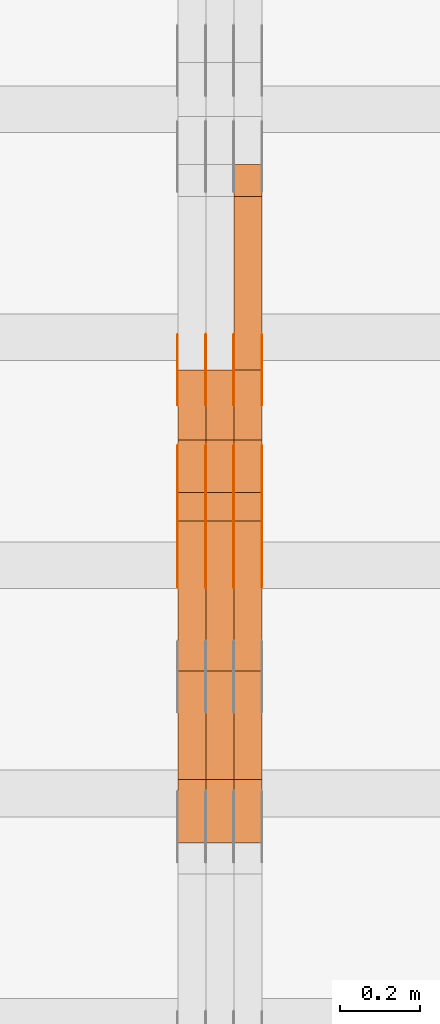
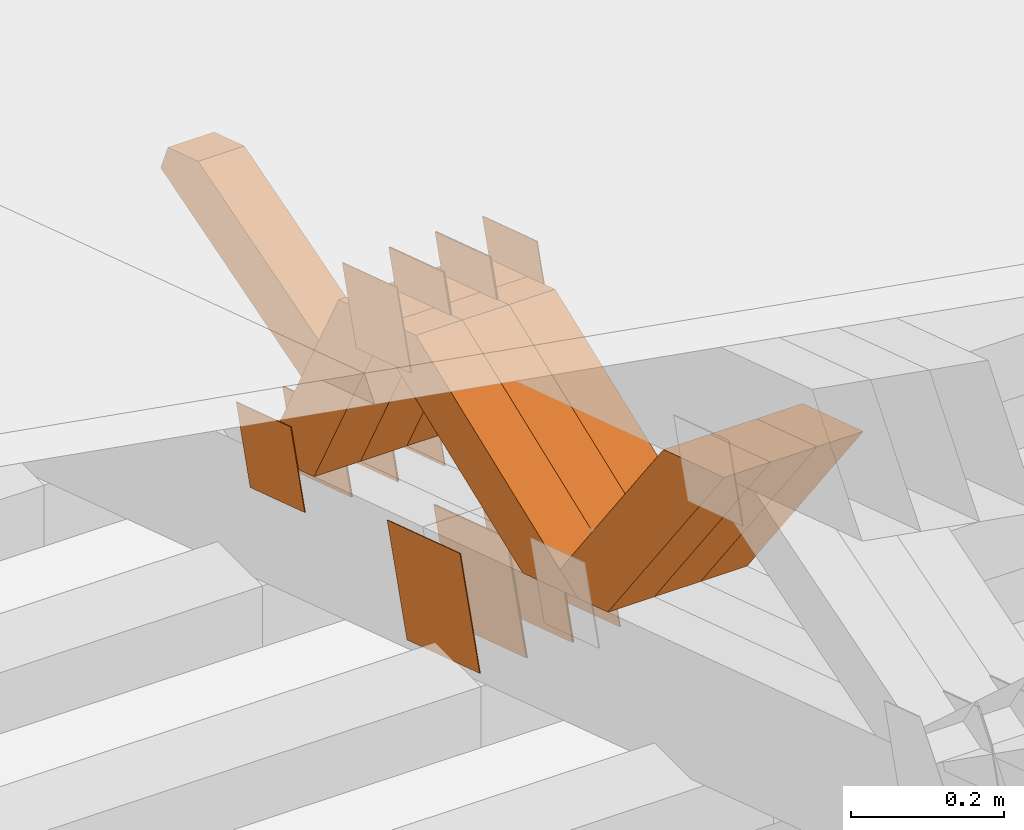
# One storey, part 216 of 385: 28 proxies.
"""IFC2X3 building model written with IfcOpenShell, lengths in millimetres."""

from ifc_helpers import new_model, entity, si_unit, converted_unit, derived_unit, direction, frame, origin, place, context, subcontext, project, spatial, polyline, outline, extrude, source, transform, mapped, material, type_object, type_shapes, element, save


model = new_model("IFC2X3")

# Units and contexts
model_context = context("Model", 3, precision=0.01, world=origin(), true_north=direction((6.12303176911189e-17, 1.0)))
body_context = subcontext(model_context, "Body", "Model", "MODEL_VIEW")
ifc_project = project(units=[si_unit("LENGTHUNIT", "METRE", prefix="MILLI"), si_unit("AREAUNIT", "SQUARE_METRE"), si_unit("VOLUMEUNIT", "CUBIC_METRE"), converted_unit("PLANEANGLEUNIT", "DEGREE", entity("IfcRatioMeasure", 0.0174532925199433), si_unit("PLANEANGLEUNIT", "RADIAN"), dimensions=[0, 0, 0, 0, 0, 0, 0]), si_unit("MASSUNIT", "GRAM", prefix="KILO"), derived_unit("MASSDENSITYUNIT", [(si_unit("MASSUNIT", "GRAM", prefix="KILO"), 1), (si_unit("LENGTHUNIT", "METRE"), -3)]), si_unit("TIMEUNIT", "SECOND"), si_unit("FREQUENCYUNIT", "HERTZ"), si_unit("THERMODYNAMICTEMPERATUREUNIT", "DEGREE_CELSIUS"), derived_unit("THERMALTRANSMITTANCEUNIT", [(si_unit("MASSUNIT", "GRAM", prefix="KILO"), 1), (si_unit("THERMODYNAMICTEMPERATUREUNIT", "KELVIN"), -1), (si_unit("TIMEUNIT", "SECOND"), -3)]), derived_unit("VOLUMETRICFLOWRATEUNIT", [(si_unit("LENGTHUNIT", "METRE"), 3), (si_unit("TIMEUNIT", "SECOND"), -1)]), si_unit("ELECTRICCURRENTUNIT", "AMPERE"), si_unit("ELECTRICVOLTAGEUNIT", "VOLT"), si_unit("POWERUNIT", "WATT"), si_unit("FORCEUNIT", "NEWTON", prefix="KILO"), si_unit("ILLUMINANCEUNIT", "LUX"), si_unit("LUMINOUSFLUXUNIT", "LUMEN"), si_unit("LUMINOUSINTENSITYUNIT", "CANDELA"), derived_unit("USERDEFINED", [(si_unit("MASSUNIT", "GRAM", prefix="KILO"), -1), (si_unit("LENGTHUNIT", "METRE"), -2), (si_unit("TIMEUNIT", "SECOND"), 3), (si_unit("LUMINOUSFLUXUNIT", "LUMEN"), 1)]), derived_unit("LINEARVELOCITYUNIT", [(si_unit("LENGTHUNIT", "METRE"), 1), (si_unit("TIMEUNIT", "SECOND"), -1)]), si_unit("PRESSUREUNIT", "PASCAL"), derived_unit("USERDEFINED", [(si_unit("LENGTHUNIT", "METRE"), -2), (si_unit("MASSUNIT", "GRAM", prefix="KILO"), 1), (si_unit("TIMEUNIT", "SECOND"), -2)])], contexts=[model_context])

# Site, building, storey
site_placement = place(None, origin())
site = spatial("IfcSite", under=ifc_project, at=site_placement, CompositionType="ELEMENT")
building_placement = place(site_placement, origin())
building = spatial("IfcBuilding", under=site, at=building_placement, CompositionType="ELEMENT")
storey_placement = place(building_placement, origin())
storey = spatial("IfcBuildingStorey", under=building, at=storey_placement, Name="Default", CompositionType="ELEMENT", Elevation=0.0)

# Proxies
ifc_material_1 = material(Name="IfcSurfaceStyle #275268")
building_element_proxy_type_1 = type_object("IfcBuildingElementProxyType", PredefinedType="NOTDEFINED", material=ifc_material_1)
shared_shape_1 = source(origin(), body_context, "Body", "SweptSolid", [
    extrude(outline(polyline([(-74.9998794200123, -59.999984515643), (74.9998565677174, -59.999984515643), (74.9998794200123, 59.999984515643), (-74.9998565677174, 59.999984515643), (-74.9998794200123, -59.999984515643)])), frame((75.0000769557496, 60.0000596852268, 0.0), z_axis=(0.0, 0.0, 1.0), x_axis=(-1.0, 0.0, 0.0)), (0.0, 0.0, 1.0), 1.3),
])
type_shapes(building_element_proxy_type_1, [shared_shape_1])
proxy_1_placement = place(building_placement, frame((21386.3, 22649.3668870864, 1282.62115477841), z_axis=(-1.0, 0.0, 0.0), x_axis=(0.0, -0.951056516295124, 0.309016994375039)))
element("IfcBuildingElementProxy", 1, at=proxy_1_placement, inside=storey, type_object=building_element_proxy_type_1, material=ifc_material_1, context=body_context, shape_type="MappedRepresentation", body=[
    mapped(shared_shape_1, transform((0.0, 0.0, 0.0), scale=1.0)),
])
ifc_material_2 = material(Name="IfcSurfaceStyle #275211")
building_element_proxy_type_2 = type_object("IfcBuildingElementProxyType", PredefinedType="NOTDEFINED", material=ifc_material_2)
shared_shape_2 = source(origin(), body_context, "Body", "SweptSolid", [
    extrude(outline(polyline([(-74.9998794200123, -59.999984515643), (74.9998565677174, -59.999984515643), (74.9998794200123, 59.999984515643), (-74.9998565677174, 59.999984515643), (-74.9998794200123, -59.999984515643)])), frame((75.0000769557496, 60.0000596852268, 0.0), z_axis=(0.0, 0.0, 1.0), x_axis=(-1.0, 0.0, 0.0)), (0.0, 0.0, 1.0), 1.3),
])
type_shapes(building_element_proxy_type_2, [shared_shape_2])
proxy_2_placement = place(building_placement, frame((21315.0, 22649.3668870864, 1282.62115477841), z_axis=(-1.0, 0.0, 0.0), x_axis=(0.0, -0.951056516295124, 0.309016994375039)))
element("IfcBuildingElementProxy", 2, at=proxy_2_placement, inside=storey, type_object=building_element_proxy_type_2, material=ifc_material_2, context=body_context, shape_type="MappedRepresentation", body=[
    mapped(shared_shape_2, transform((0.0, 0.0, 0.0), scale=1.0)),
])
ifc_material_3 = material(Name="IfcSurfaceStyle #275154")
building_element_proxy_type_3 = type_object("IfcBuildingElementProxyType", PredefinedType="NOTDEFINED", material=ifc_material_3)
shared_shape_3 = source(origin(), body_context, "Body", "SweptSolid", [
    extrude(outline(polyline([(-74.9998794200123, -59.999984515643), (74.9998565677174, -59.999984515643), (74.9998794200123, 59.999984515643), (-74.9998565677174, 59.999984515643), (-74.9998794200123, -59.999984515643)])), frame((75.0000769557496, 60.0000596852268, 0.0), z_axis=(0.0, 0.0, 1.0), x_axis=(-1.0, 0.0, 0.0)), (0.0, 0.0, 1.0), 1.3),
])
type_shapes(building_element_proxy_type_3, [shared_shape_3])
proxy_3_placement = place(building_placement, frame((21316.3, 22649.3668870864, 1282.62115477841), z_axis=(-1.0, 0.0, 0.0), x_axis=(0.0, -0.951056516295124, 0.309016994375039)))
element("IfcBuildingElementProxy", 3, at=proxy_3_placement, inside=storey, type_object=building_element_proxy_type_3, material=ifc_material_3, context=body_context, shape_type="MappedRepresentation", body=[
    mapped(shared_shape_3, transform((0.0, 0.0, 0.0), scale=1.0)),
])
ifc_material_4 = material(Name="IfcSurfaceStyle #275097")
building_element_proxy_type_4 = type_object("IfcBuildingElementProxyType", PredefinedType="NOTDEFINED", material=ifc_material_4)
shared_shape_4 = source(origin(), body_context, "Body", "SweptSolid", [
    extrude(outline(polyline([(-74.9998794200123, -59.999984515643), (74.9998565677174, -59.999984515643), (74.9998794200123, 59.999984515643), (-74.9998565677174, 59.999984515643), (-74.9998794200123, -59.999984515643)])), frame((75.0000769557496, 60.0000596852268, 0.0), z_axis=(0.0, 0.0, 1.0), x_axis=(-1.0, 0.0, 0.0)), (0.0, 0.0, 1.0), 1.29999999999999),
])
type_shapes(building_element_proxy_type_4, [shared_shape_4])
proxy_4_placement = place(building_placement, frame((21245.0, 22649.3668870864, 1282.62115477841), z_axis=(-1.0, 0.0, 0.0), x_axis=(0.0, -0.951056516295124, 0.309016994375039)))
element("IfcBuildingElementProxy", 4, at=proxy_4_placement, inside=storey, type_object=building_element_proxy_type_4, material=ifc_material_4, context=body_context, shape_type="MappedRepresentation", body=[
    mapped(shared_shape_4, transform((0.0, 0.0, 0.0), scale=1.0)),
])
ifc_material_5 = material(Name="IfcSurfaceStyle #275040")
building_element_proxy_type_5 = type_object("IfcBuildingElementProxyType", PredefinedType="NOTDEFINED", material=ifc_material_5)
shared_shape_5 = source(origin(), body_context, "Body", "SweptSolid", [
    extrude(outline(polyline([(-74.9998794200123, -59.999984515643), (74.9998565677174, -59.999984515643), (74.9998794200123, 59.999984515643), (-74.9998565677174, 59.999984515643), (-74.9998794200123, -59.999984515643)])), frame((75.0000769557496, 60.0000596852268, 0.0), z_axis=(0.0, 0.0, 1.0), x_axis=(-1.0, 0.0, 0.0)), (0.0, 0.0, 1.0), 1.29999999999999),
])
type_shapes(building_element_proxy_type_5, [shared_shape_5])
proxy_5_placement = place(building_placement, frame((21246.3, 22649.3668870864, 1282.62115477841), z_axis=(-1.0, 0.0, 0.0), x_axis=(0.0, -0.951056516295124, 0.309016994375039)))
element("IfcBuildingElementProxy", 5, at=proxy_5_placement, inside=storey, type_object=building_element_proxy_type_5, material=ifc_material_5, context=body_context, shape_type="MappedRepresentation", body=[
    mapped(shared_shape_5, transform((0.0, 0.0, 0.0), scale=1.0)),
])
ifc_material_6 = material(Name="IfcSurfaceStyle #274983")
building_element_proxy_type_6 = type_object("IfcBuildingElementProxyType", PredefinedType="NOTDEFINED", material=ifc_material_6)
shared_shape_6 = source(origin(), body_context, "Body", "SweptSolid", [
    extrude(outline(polyline([(-74.9998794200123, -59.999984515643), (74.9998565677174, -59.999984515643), (74.9998794200123, 59.999984515643), (-74.9998565677174, 59.999984515643), (-74.9998794200123, -59.999984515643)])), frame((75.0000769557496, 60.0000596852268, 0.0), z_axis=(0.0, 0.0, 1.0), x_axis=(-1.0, 0.0, 0.0)), (0.0, 0.0, 1.0), 1.29999999999999),
])
type_shapes(building_element_proxy_type_6, [shared_shape_6])
proxy_6_placement = place(building_placement, frame((21175.0, 22649.3668870864, 1282.62115477841), z_axis=(-1.0, 0.0, 0.0), x_axis=(0.0, -0.951056516295124, 0.309016994375039)))
element("IfcBuildingElementProxy", 6, at=proxy_6_placement, inside=storey, type_object=building_element_proxy_type_6, material=ifc_material_6, context=body_context, shape_type="MappedRepresentation", body=[
    mapped(shared_shape_6, transform((0.0, 0.0, 0.0), scale=1.0)),
])
ifc_material_7 = material(Name="IfcSurfaceStyle #274584")
building_element_proxy_type_7 = type_object("IfcBuildingElementProxyType", PredefinedType="NOTDEFINED", material=ifc_material_7)
shared_shape_7 = source(origin(), body_context, "Body", "SweptSolid", [
    extrude(outline(polyline([(-99.9999579276585, -84.0000593595837), (100.000141865112, -84.0000593595837), (99.9999579276589, 84.0000593595837), (-100.000141865112, 84.0000593595837), (-99.9999579276585, -84.0000593595837)])), frame((100.000141865112, 84.0000593595837, 0.0), z_axis=(0.0, 0.0, 1.0), x_axis=(-1.0, 0.0, 0.0)), (0.0, 0.0, 1.0), 1.3),
])
type_shapes(building_element_proxy_type_7, [shared_shape_7])
proxy_7_placement = place(building_placement, frame((21386.3, 22239.7296395088, 1287.96775368191), z_axis=(-1.0, 0.0, 0.0), x_axis=(0.0, -0.951056516295124, 0.309016994375039)))
element("IfcBuildingElementProxy", 7, at=proxy_7_placement, inside=storey, type_object=building_element_proxy_type_7, material=ifc_material_7, context=body_context, shape_type="MappedRepresentation", body=[
    mapped(shared_shape_7, transform((0.0, 0.0, 0.0), scale=1.0)),
])
ifc_material_8 = material(Name="IfcSurfaceStyle #274527")
building_element_proxy_type_8 = type_object("IfcBuildingElementProxyType", PredefinedType="NOTDEFINED", material=ifc_material_8)
shared_shape_8 = source(origin(), body_context, "Body", "SweptSolid", [
    extrude(outline(polyline([(-99.9999579276585, -84.0000593595837), (100.000141865112, -84.0000593595837), (99.9999579276589, 84.0000593595837), (-100.000141865112, 84.0000593595837), (-99.9999579276585, -84.0000593595837)])), frame((100.000141865112, 84.0000593595837, 0.0), z_axis=(0.0, 0.0, 1.0), x_axis=(-1.0, 0.0, 0.0)), (0.0, 0.0, 1.0), 1.3),
])
type_shapes(building_element_proxy_type_8, [shared_shape_8])
proxy_8_placement = place(building_placement, frame((21315.0, 22239.7296395088, 1287.96775368191), z_axis=(-1.0, 0.0, 0.0), x_axis=(0.0, -0.951056516295124, 0.309016994375039)))
element("IfcBuildingElementProxy", 8, at=proxy_8_placement, inside=storey, type_object=building_element_proxy_type_8, material=ifc_material_8, context=body_context, shape_type="MappedRepresentation", body=[
    mapped(shared_shape_8, transform((0.0, 0.0, 0.0), scale=1.0)),
])
ifc_material_9 = material(Name="IfcSurfaceStyle #274470")
building_element_proxy_type_9 = type_object("IfcBuildingElementProxyType", PredefinedType="NOTDEFINED", material=ifc_material_9)
shared_shape_9 = source(origin(), body_context, "Body", "SweptSolid", [
    extrude(outline(polyline([(-99.9999579276585, -84.0000593595837), (100.000141865112, -84.0000593595837), (99.9999579276589, 84.0000593595837), (-100.000141865112, 84.0000593595837), (-99.9999579276585, -84.0000593595837)])), frame((100.000141865112, 84.0000593595837, 0.0), z_axis=(0.0, 0.0, 1.0), x_axis=(-1.0, 0.0, 0.0)), (0.0, 0.0, 1.0), 1.3),
])
type_shapes(building_element_proxy_type_9, [shared_shape_9])
proxy_9_placement = place(building_placement, frame((21316.3, 22239.7296395088, 1287.96775368191), z_axis=(-1.0, 0.0, 0.0), x_axis=(0.0, -0.951056516295124, 0.309016994375039)))
element("IfcBuildingElementProxy", 9, at=proxy_9_placement, inside=storey, type_object=building_element_proxy_type_9, material=ifc_material_9, context=body_context, shape_type="MappedRepresentation", body=[
    mapped(shared_shape_9, transform((0.0, 0.0, 0.0), scale=1.0)),
])
ifc_material_10 = material(Name="IfcSurfaceStyle #274413")
building_element_proxy_type_10 = type_object("IfcBuildingElementProxyType", PredefinedType="NOTDEFINED", material=ifc_material_10)
shared_shape_10 = source(origin(), body_context, "Body", "SweptSolid", [
    extrude(outline(polyline([(-99.9999579276585, -84.0000593595837), (100.000141865112, -84.0000593595837), (99.9999579276589, 84.0000593595837), (-100.000141865112, 84.0000593595837), (-99.9999579276585, -84.0000593595837)])), frame((100.000141865112, 84.0000593595837, 0.0), z_axis=(0.0, 0.0, 1.0), x_axis=(-1.0, 0.0, 0.0)), (0.0, 0.0, 1.0), 1.29999999999998),
])
type_shapes(building_element_proxy_type_10, [shared_shape_10])
proxy_10_placement = place(building_placement, frame((21245.0, 22239.7296395088, 1287.96775368191), z_axis=(-1.0, 0.0, 0.0), x_axis=(0.0, -0.951056516295124, 0.309016994375039)))
element("IfcBuildingElementProxy", 10, at=proxy_10_placement, inside=storey, type_object=building_element_proxy_type_10, material=ifc_material_10, context=body_context, shape_type="MappedRepresentation", body=[
    mapped(shared_shape_10, transform((0.0, 0.0, 0.0), scale=1.0)),
])
ifc_material_11 = material(Name="IfcSurfaceStyle #274356")
building_element_proxy_type_11 = type_object("IfcBuildingElementProxyType", PredefinedType="NOTDEFINED", material=ifc_material_11)
shared_shape_11 = source(origin(), body_context, "Body", "SweptSolid", [
    extrude(outline(polyline([(-99.9999579276585, -84.0000593595837), (100.000141865112, -84.0000593595837), (99.9999579276589, 84.0000593595837), (-100.000141865112, 84.0000593595837), (-99.9999579276585, -84.0000593595837)])), frame((100.000141865112, 84.0000593595837, 0.0), z_axis=(0.0, 0.0, 1.0), x_axis=(-1.0, 0.0, 0.0)), (0.0, 0.0, 1.0), 1.29999999999998),
])
type_shapes(building_element_proxy_type_11, [shared_shape_11])
proxy_11_placement = place(building_placement, frame((21246.3, 22239.7296395088, 1287.96775368191), z_axis=(-1.0, 0.0, 0.0), x_axis=(0.0, -0.951056516295124, 0.309016994375039)))
element("IfcBuildingElementProxy", 11, at=proxy_11_placement, inside=storey, type_object=building_element_proxy_type_11, material=ifc_material_11, context=body_context, shape_type="MappedRepresentation", body=[
    mapped(shared_shape_11, transform((0.0, 0.0, 0.0), scale=1.0)),
])
ifc_material_12 = material(Name="IfcSurfaceStyle #274299")
building_element_proxy_type_12 = type_object("IfcBuildingElementProxyType", PredefinedType="NOTDEFINED", material=ifc_material_12)
shared_shape_12 = source(origin(), body_context, "Body", "SweptSolid", [
    extrude(outline(polyline([(-99.9999579276585, -84.0000593595837), (100.000141865112, -84.0000593595837), (99.9999579276589, 84.0000593595837), (-100.000141865112, 84.0000593595837), (-99.9999579276585, -84.0000593595837)])), frame((100.000141865112, 84.0000593595837, 0.0), z_axis=(0.0, 0.0, 1.0), x_axis=(-1.0, 0.0, 0.0)), (0.0, 0.0, 1.0), 1.29999999999999),
])
type_shapes(building_element_proxy_type_12, [shared_shape_12])
proxy_12_placement = place(building_placement, frame((21175.0, 22239.7296395088, 1287.96775368191), z_axis=(-1.0, 0.0, 0.0), x_axis=(0.0, -0.951056516295124, 0.309016994375039)))
element("IfcBuildingElementProxy", 12, at=proxy_12_placement, inside=storey, type_object=building_element_proxy_type_12, material=ifc_material_12, context=body_context, shape_type="MappedRepresentation", body=[
    mapped(shared_shape_12, transform((0.0, 0.0, 0.0), scale=1.0)),
])
ifc_material_13 = material(Name="IfcSurfaceStyle #266034")
building_element_proxy_type_13 = type_object("IfcBuildingElementProxyType", PredefinedType="NOTDEFINED", material=ifc_material_13)
shared_shape_13 = source(origin(), body_context, "Body", "SweptSolid", [
    extrude(outline(polyline([(-74.9998794200069, -59.9999845156358), (74.9998565677229, -59.9999845156358), (74.9998794200069, 59.9999845156358), (-74.9998565677229, 59.9999845156358), (-74.9998794200069, -59.9999845156358)])), frame((75.0000966453795, 60.0000596852335, 0.0), z_axis=(0.0, 0.0, 1.0), x_axis=(-1.0, 0.0, 0.0)), (0.0, 0.0, 1.0), 1.3),
])
type_shapes(building_element_proxy_type_13, [shared_shape_13])
proxy_13_placement = place(building_placement, frame((21386.3, 22372.1881948749, 1673.08440552992), z_axis=(-1.0, 0.0, 0.0), x_axis=(0.0, -0.951056516295154, 0.309016994374948)))
element("IfcBuildingElementProxy", 13, at=proxy_13_placement, inside=storey, type_object=building_element_proxy_type_13, material=ifc_material_13, context=body_context, shape_type="MappedRepresentation", body=[
    mapped(shared_shape_13, transform((0.0, 0.0, 0.0), scale=1.0)),
])
ifc_material_14 = material(Name="IfcSurfaceStyle #265977")
building_element_proxy_type_14 = type_object("IfcBuildingElementProxyType", PredefinedType="NOTDEFINED", material=ifc_material_14)
shared_shape_14 = source(origin(), body_context, "Body", "SweptSolid", [
    extrude(outline(polyline([(-74.9998794200069, -59.9999845156358), (74.9998565677229, -59.9999845156358), (74.9998794200069, 59.9999845156358), (-74.9998565677229, 59.9999845156358), (-74.9998794200069, -59.9999845156358)])), frame((75.0000966453795, 60.0000596852335, 0.0), z_axis=(0.0, 0.0, 1.0), x_axis=(-1.0, 0.0, 0.0)), (0.0, 0.0, 1.0), 1.3),
])
type_shapes(building_element_proxy_type_14, [shared_shape_14])
proxy_14_placement = place(building_placement, frame((21315.0, 22372.1881948749, 1673.08440552992), z_axis=(-1.0, 0.0, 0.0), x_axis=(0.0, -0.951056516295154, 0.309016994374948)))
element("IfcBuildingElementProxy", 14, at=proxy_14_placement, inside=storey, type_object=building_element_proxy_type_14, material=ifc_material_14, context=body_context, shape_type="MappedRepresentation", body=[
    mapped(shared_shape_14, transform((0.0, 0.0, 0.0), scale=1.0)),
])
ifc_material_15 = material(Name="IfcSurfaceStyle #265920")
building_element_proxy_type_15 = type_object("IfcBuildingElementProxyType", PredefinedType="NOTDEFINED", material=ifc_material_15)
shared_shape_15 = source(origin(), body_context, "Body", "SweptSolid", [
    extrude(outline(polyline([(-74.9998794200069, -59.9999845156358), (74.9998565677229, -59.9999845156358), (74.9998794200069, 59.9999845156358), (-74.9998565677229, 59.9999845156358), (-74.9998794200069, -59.9999845156358)])), frame((75.0000966453795, 60.0000596852335, 0.0), z_axis=(0.0, 0.0, 1.0), x_axis=(-1.0, 0.0, 0.0)), (0.0, 0.0, 1.0), 1.3),
])
type_shapes(building_element_proxy_type_15, [shared_shape_15])
proxy_15_placement = place(building_placement, frame((21316.3, 22372.1881948749, 1673.08440552992), z_axis=(-1.0, 0.0, 0.0), x_axis=(0.0, -0.951056516295154, 0.309016994374948)))
element("IfcBuildingElementProxy", 15, at=proxy_15_placement, inside=storey, type_object=building_element_proxy_type_15, material=ifc_material_15, context=body_context, shape_type="MappedRepresentation", body=[
    mapped(shared_shape_15, transform((0.0, 0.0, 0.0), scale=1.0)),
])
ifc_material_16 = material(Name="IfcSurfaceStyle #265863")
building_element_proxy_type_16 = type_object("IfcBuildingElementProxyType", PredefinedType="NOTDEFINED", material=ifc_material_16)
shared_shape_16 = source(origin(), body_context, "Body", "SweptSolid", [
    extrude(outline(polyline([(-74.9998794200069, -59.9999845156358), (74.9998565677229, -59.9999845156358), (74.9998794200069, 59.9999845156358), (-74.9998565677229, 59.9999845156358), (-74.9998794200069, -59.9999845156358)])), frame((75.0000966453795, 60.0000596852335, 0.0), z_axis=(0.0, 0.0, 1.0), x_axis=(-1.0, 0.0, 0.0)), (0.0, 0.0, 1.0), 1.29999999999999),
])
type_shapes(building_element_proxy_type_16, [shared_shape_16])
proxy_16_placement = place(building_placement, frame((21245.0, 22372.1881948749, 1673.08440552992), z_axis=(-1.0, 0.0, 0.0), x_axis=(0.0, -0.951056516295154, 0.309016994374948)))
element("IfcBuildingElementProxy", 16, at=proxy_16_placement, inside=storey, type_object=building_element_proxy_type_16, material=ifc_material_16, context=body_context, shape_type="MappedRepresentation", body=[
    mapped(shared_shape_16, transform((0.0, 0.0, 0.0), scale=1.0)),
])
ifc_material_17 = material(Name="IfcSurfaceStyle #265806")
building_element_proxy_type_17 = type_object("IfcBuildingElementProxyType", PredefinedType="NOTDEFINED", material=ifc_material_17)
shared_shape_17 = source(origin(), body_context, "Body", "SweptSolid", [
    extrude(outline(polyline([(-74.9998794200069, -59.9999845156358), (74.9998565677229, -59.9999845156358), (74.9998794200069, 59.9999845156358), (-74.9998565677229, 59.9999845156358), (-74.9998794200069, -59.9999845156358)])), frame((75.0000966453795, 60.0000596852335, 0.0), z_axis=(0.0, 0.0, 1.0), x_axis=(-1.0, 0.0, 0.0)), (0.0, 0.0, 1.0), 1.29999999999999),
])
type_shapes(building_element_proxy_type_17, [shared_shape_17])
proxy_17_placement = place(building_placement, frame((21246.3, 22372.1881948749, 1673.08440552992), z_axis=(-1.0, 0.0, 0.0), x_axis=(0.0, -0.951056516295154, 0.309016994374948)))
element("IfcBuildingElementProxy", 17, at=proxy_17_placement, inside=storey, type_object=building_element_proxy_type_17, material=ifc_material_17, context=body_context, shape_type="MappedRepresentation", body=[
    mapped(shared_shape_17, transform((0.0, 0.0, 0.0), scale=1.0)),
])
ifc_material_18 = material(Name="IfcSurfaceStyle #265749")
building_element_proxy_type_18 = type_object("IfcBuildingElementProxyType", PredefinedType="NOTDEFINED", material=ifc_material_18)
shared_shape_18 = source(origin(), body_context, "Body", "SweptSolid", [
    extrude(outline(polyline([(-74.9998794200069, -59.9999845156358), (74.9998565677229, -59.9999845156358), (74.9998794200069, 59.9999845156358), (-74.9998565677229, 59.9999845156358), (-74.9998794200069, -59.9999845156358)])), frame((75.0000966453795, 60.0000596852335, 0.0), z_axis=(0.0, 0.0, 1.0), x_axis=(-1.0, 0.0, 0.0)), (0.0, 0.0, 1.0), 1.29999999999999),
])
type_shapes(building_element_proxy_type_18, [shared_shape_18])
proxy_18_placement = place(building_placement, frame((21175.0, 22372.1881948749, 1673.08440552992), z_axis=(-1.0, 0.0, 0.0), x_axis=(0.0, -0.951056516295154, 0.309016994374948)))
element("IfcBuildingElementProxy", 18, at=proxy_18_placement, inside=storey, type_object=building_element_proxy_type_18, material=ifc_material_18, context=body_context, shape_type="MappedRepresentation", body=[
    mapped(shared_shape_18, transform((0.0, 0.0, 0.0), scale=1.0)),
])
ifc_material_19 = material(Name="IfcSurfaceStyle #254082")
building_element_proxy_type_19 = type_object("IfcBuildingElementProxyType", Name="T1-W18 254080", PredefinedType="NOTDEFINED", material=ifc_material_19)
shared_shape_19 = source(origin(), body_context, "Body", "SweptSolid", [
    extrude(outline(polyline([(-221.504996322134, -47.4999929258616), (225.406467948779, -47.4999929258616), (211.663832468686, -0.000107703153482008), (143.08905281687, 47.5000467774384), (-358.6543569122, 47.5000467774384), (-221.504996322134, -47.4999929258616)])), frame((225.406576158364, 47.5000467774384, 0.0), z_axis=(0.0, 0.0, 1.0), x_axis=(-1.0, 0.0, 0.0)), (0.0, 0.0, 1.0), 70.0),
])
type_shapes(building_element_proxy_type_19, [shared_shape_19])
proxy_19_placement = place(building_placement, frame((21385.0, 21766.9513837803, 1583.13813361817), z_axis=(-1.0, 0.0, 0.0), x_axis=(0.0, -0.605858491298265, 0.795572428206126)))
element("IfcBuildingElementProxy", 19, at=proxy_19_placement, inside=storey, type_object=building_element_proxy_type_19, material=ifc_material_19, Name="T1-W18", context=body_context, shape_type="MappedRepresentation", body=[
    mapped(shared_shape_19, transform((0.0, 0.0, 0.0), scale=1.0)),
])
ifc_material_20 = material(Name="IfcSurfaceStyle #254016")
building_element_proxy_type_20 = type_object("IfcBuildingElementProxyType", Name="T1-W18 254014", PredefinedType="NOTDEFINED", material=ifc_material_20)
shared_shape_20 = source(origin(), body_context, "Body", "SweptSolid", [
    extrude(outline(polyline([(-221.504996322134, -47.4999929258616), (225.406467948779, -47.4999929258616), (211.663832468686, -0.000107703153482008), (143.08905281687, 47.5000467774384), (-358.6543569122, 47.5000467774384), (-221.504996322134, -47.4999929258616)])), frame((225.406576158364, 47.5000467774384, 0.0), z_axis=(0.0, 0.0, 1.0), x_axis=(-1.0, 0.0, 0.0)), (0.0, 0.0, 1.0), 70.0),
])
type_shapes(building_element_proxy_type_20, [shared_shape_20])
proxy_20_placement = place(building_placement, frame((21315.0, 21766.9513837803, 1583.13813361817), z_axis=(-1.0, 0.0, 0.0), x_axis=(0.0, -0.605858491298265, 0.795572428206126)))
element("IfcBuildingElementProxy", 20, at=proxy_20_placement, inside=storey, type_object=building_element_proxy_type_20, material=ifc_material_20, Name="T1-W18", context=body_context, shape_type="MappedRepresentation", body=[
    mapped(shared_shape_20, transform((0.0, 0.0, 0.0), scale=1.0)),
])
ifc_material_21 = material(Name="IfcSurfaceStyle #253950")
building_element_proxy_type_21 = type_object("IfcBuildingElementProxyType", Name="T1-W18 253948", PredefinedType="NOTDEFINED", material=ifc_material_21)
shared_shape_21 = source(origin(), body_context, "Body", "SweptSolid", [
    extrude(outline(polyline([(-221.504996322134, -47.4999929258616), (225.406467948779, -47.4999929258616), (211.663832468686, -0.000107703153482008), (143.08905281687, 47.5000467774384), (-358.6543569122, 47.5000467774384), (-221.504996322134, -47.4999929258616)])), frame((225.406576158364, 47.5000467774384, 0.0), z_axis=(0.0, 0.0, 1.0), x_axis=(-1.0, 0.0, 0.0)), (0.0, 0.0, 1.0), 70.0),
])
type_shapes(building_element_proxy_type_21, [shared_shape_21])
proxy_21_placement = place(building_placement, frame((21245.0, 21766.9513837803, 1583.13813361817), z_axis=(-1.0, 0.0, 0.0), x_axis=(0.0, -0.605858491298265, 0.795572428206126)))
element("IfcBuildingElementProxy", 21, at=proxy_21_placement, inside=storey, type_object=building_element_proxy_type_21, material=ifc_material_21, Name="T1-W18", context=body_context, shape_type="MappedRepresentation", body=[
    mapped(shared_shape_21, transform((0.0, 0.0, 0.0), scale=1.0)),
])
ifc_material_22 = material(Name="IfcSurfaceStyle #253686")
building_element_proxy_type_22 = type_object("IfcBuildingElementProxyType", Name="T1-W30 253684", PredefinedType="NOTDEFINED", material=ifc_material_22)
shared_shape_22 = source(origin(), body_context, "Body", "SweptSolid", [
    extrude(outline(polyline([(-319.322304176575, -47.5000259045904), (133.154090927094, -47.5000259045904), (191.489196707701, 6.99403755251016e-06), (197.330697834052, 47.5000224075717), (-202.651681292271, 47.5000224075717), (-319.322304176575, -47.5000259045904)])), frame((197.330834478517, 47.5000608592405, 0.0), z_axis=(0.0, 0.0, 1.0), x_axis=(-1.0, 0.0, 0.0)), (0.0, 0.0, 1.0), 70.0),
])
type_shapes(building_element_proxy_type_22, [shared_shape_22])
proxy_22_placement = place(building_placement, frame((21385.0, 22312.5352975627, 1720.70362673362), z_axis=(-1.0, 0.0, 0.0), x_axis=(0.0, -0.932610696879359, -0.360884036868072)))
element("IfcBuildingElementProxy", 22, at=proxy_22_placement, inside=storey, type_object=building_element_proxy_type_22, material=ifc_material_22, Name="T1-W30", context=body_context, shape_type="MappedRepresentation", body=[
    mapped(shared_shape_22, transform((0.0, 0.0, 0.0), scale=1.0)),
])
ifc_material_23 = material(Name="IfcSurfaceStyle #253620")
building_element_proxy_type_23 = type_object("IfcBuildingElementProxyType", Name="T1-W30 253618", PredefinedType="NOTDEFINED", material=ifc_material_23)
shared_shape_23 = source(origin(), body_context, "Body", "SweptSolid", [
    extrude(outline(polyline([(-319.322304176575, -47.5000259045904), (133.154090927094, -47.5000259045904), (191.489196707701, 6.99403755251016e-06), (197.330697834052, 47.5000224075717), (-202.651681292271, 47.5000224075717), (-319.322304176575, -47.5000259045904)])), frame((197.330834478517, 47.5000608592405, 0.0), z_axis=(0.0, 0.0, 1.0), x_axis=(-1.0, 0.0, 0.0)), (0.0, 0.0, 1.0), 70.0),
])
type_shapes(building_element_proxy_type_23, [shared_shape_23])
proxy_23_placement = place(building_placement, frame((21315.0, 22312.5352975627, 1720.70362673362), z_axis=(-1.0, 0.0, 0.0), x_axis=(0.0, -0.932610696879359, -0.360884036868072)))
element("IfcBuildingElementProxy", 23, at=proxy_23_placement, inside=storey, type_object=building_element_proxy_type_23, material=ifc_material_23, Name="T1-W30", context=body_context, shape_type="MappedRepresentation", body=[
    mapped(shared_shape_23, transform((0.0, 0.0, 0.0), scale=1.0)),
])
ifc_material_24 = material(Name="IfcSurfaceStyle #253554")
building_element_proxy_type_24 = type_object("IfcBuildingElementProxyType", Name="T1-W30 253552", PredefinedType="NOTDEFINED", material=ifc_material_24)
shared_shape_24 = source(origin(), body_context, "Body", "SweptSolid", [
    extrude(outline(polyline([(-319.322304176575, -47.5000259045904), (133.154090927094, -47.5000259045904), (191.489196707701, 6.99403755251016e-06), (197.330697834052, 47.5000224075717), (-202.651681292271, 47.5000224075717), (-319.322304176575, -47.5000259045904)])), frame((197.330834478517, 47.5000608592405, 0.0), z_axis=(0.0, 0.0, 1.0), x_axis=(-1.0, 0.0, 0.0)), (0.0, 0.0, 1.0), 70.0),
])
type_shapes(building_element_proxy_type_24, [shared_shape_24])
proxy_24_placement = place(building_placement, frame((21245.0, 22312.5352975627, 1720.70362673362), z_axis=(-1.0, 0.0, 0.0), x_axis=(0.0, -0.932610696879359, -0.360884036868072)))
element("IfcBuildingElementProxy", 24, at=proxy_24_placement, inside=storey, type_object=building_element_proxy_type_24, material=ifc_material_24, Name="T1-W30", context=body_context, shape_type="MappedRepresentation", body=[
    mapped(shared_shape_24, transform((0.0, 0.0, 0.0), scale=1.0)),
])
ifc_material_25 = material(Name="IfcSurfaceStyle #253290")
building_element_proxy_type_25 = type_object("IfcBuildingElementProxyType", Name="T1-W41 253288", PredefinedType="NOTDEFINED", material=ifc_material_25)
shared_shape_25 = source(origin(), body_context, "Body", "SweptSolid", [
    extrude(outline(polyline([(-190.064783497519, -47.5001011048749), (182.590736871656, -47.5001011048749), (172.978793750747, 0.000111395300689243), (123.505951450908, 47.5000454072246), (-289.010698575792, 47.5000454072246), (-190.064783497519, -47.5001011048749)])), frame((182.590736871656, 47.5001973817447, 0.0), z_axis=(0.0, 0.0, 1.0), x_axis=(-1.0, 0.0, 0.0)), (0.0, 0.0, 1.0), 70.0),
])
type_shapes(building_element_proxy_type_25, [shared_shape_25])
proxy_25_placement = place(building_placement, frame((21385.0, 22512.5506969063, 1347.13648051689), z_axis=(-1.0, 0.0, 0.0), x_axis=(0.0, -0.472020158706979, 0.881587755004706)))
element("IfcBuildingElementProxy", 25, at=proxy_25_placement, inside=storey, type_object=building_element_proxy_type_25, material=ifc_material_25, Name="T1-W41", context=body_context, shape_type="MappedRepresentation", body=[
    mapped(shared_shape_25, transform((0.0, 0.0, 0.0), scale=1.0)),
])
ifc_material_26 = material(Name="IfcSurfaceStyle #253224")
building_element_proxy_type_26 = type_object("IfcBuildingElementProxyType", Name="T1-W41 253222", PredefinedType="NOTDEFINED", material=ifc_material_26)
shared_shape_26 = source(origin(), body_context, "Body", "SweptSolid", [
    extrude(outline(polyline([(-190.064783497519, -47.5001011048749), (182.590736871656, -47.5001011048749), (172.978793750747, 0.000111395300689243), (123.505951450908, 47.5000454072246), (-289.010698575792, 47.5000454072246), (-190.064783497519, -47.5001011048749)])), frame((182.590736871656, 47.5001973817447, 0.0), z_axis=(0.0, 0.0, 1.0), x_axis=(-1.0, 0.0, 0.0)), (0.0, 0.0, 1.0), 70.0),
])
type_shapes(building_element_proxy_type_26, [shared_shape_26])
proxy_26_placement = place(building_placement, frame((21315.0, 22512.5506969063, 1347.13648051689), z_axis=(-1.0, 0.0, 0.0), x_axis=(0.0, -0.472020158706979, 0.881587755004706)))
element("IfcBuildingElementProxy", 26, at=proxy_26_placement, inside=storey, type_object=building_element_proxy_type_26, material=ifc_material_26, Name="T1-W41", context=body_context, shape_type="MappedRepresentation", body=[
    mapped(shared_shape_26, transform((0.0, 0.0, 0.0), scale=1.0)),
])
ifc_material_27 = material(Name="IfcSurfaceStyle #253158")
building_element_proxy_type_27 = type_object("IfcBuildingElementProxyType", Name="T1-W41 253156", PredefinedType="NOTDEFINED", material=ifc_material_27)
shared_shape_27 = source(origin(), body_context, "Body", "SweptSolid", [
    extrude(outline(polyline([(-190.064783497519, -47.5001011048749), (182.590736871656, -47.5001011048749), (172.978793750747, 0.000111395300689243), (123.505951450908, 47.5000454072246), (-289.010698575792, 47.5000454072246), (-190.064783497519, -47.5001011048749)])), frame((182.590736871656, 47.5001973817447, 0.0), z_axis=(0.0, 0.0, 1.0), x_axis=(-1.0, 0.0, 0.0)), (0.0, 0.0, 1.0), 70.0),
])
type_shapes(building_element_proxy_type_27, [shared_shape_27])
proxy_27_placement = place(building_placement, frame((21245.0, 22512.5506969063, 1347.13648051689), z_axis=(-1.0, 0.0, 0.0), x_axis=(0.0, -0.472020158706979, 0.881587755004706)))
element("IfcBuildingElementProxy", 27, at=proxy_27_placement, inside=storey, type_object=building_element_proxy_type_27, material=ifc_material_27, Name="T1-W41", context=body_context, shape_type="MappedRepresentation", body=[
    mapped(shared_shape_27, transform((0.0, 0.0, 0.0), scale=1.0)),
])
ifc_material_28 = material(Name="IfcSurfaceStyle #252894")
building_element_proxy_type_28 = type_object("IfcBuildingElementProxyType", Name="T1-W23 252892", PredefinedType="NOTDEFINED", material=ifc_material_28)
shared_shape_28 = source(origin(), body_context, "Body", "SweptSolid", [
    extrude(outline(polyline([(-356.808656505462, -47.5000180192671), (144.726334557508, -47.5000180192671), (213.258834104997, -2.90494310381195e-05), (218.567145253444, 47.5000325439826), (-219.743657410487, 47.5000325439827), (-356.808656505462, -47.5000180192671)])), frame((218.567145253444, 47.5000325439826, 0.0), z_axis=(0.0, 0.0, 1.0), x_axis=(-1.0, 0.0, 0.0)), (0.0, 0.0, 1.0), 70.0),
])
type_shapes(building_element_proxy_type_28, [shared_shape_28])
proxy_28_placement = place(building_placement, frame((21385.0, 23128.2626953125, 1452.63940429688), z_axis=(-1.0, 0.0, 0.0), x_axis=(0.0, -0.957692700226705, -0.287792793399143)))
element("IfcBuildingElementProxy", 28, at=proxy_28_placement, inside=storey, type_object=building_element_proxy_type_28, material=ifc_material_28, Name="T1-W23", context=body_context, shape_type="MappedRepresentation", body=[
    mapped(shared_shape_28, transform((0.0, 0.0, 0.0), scale=1.0)),
])

save(model, "model.ifc")
